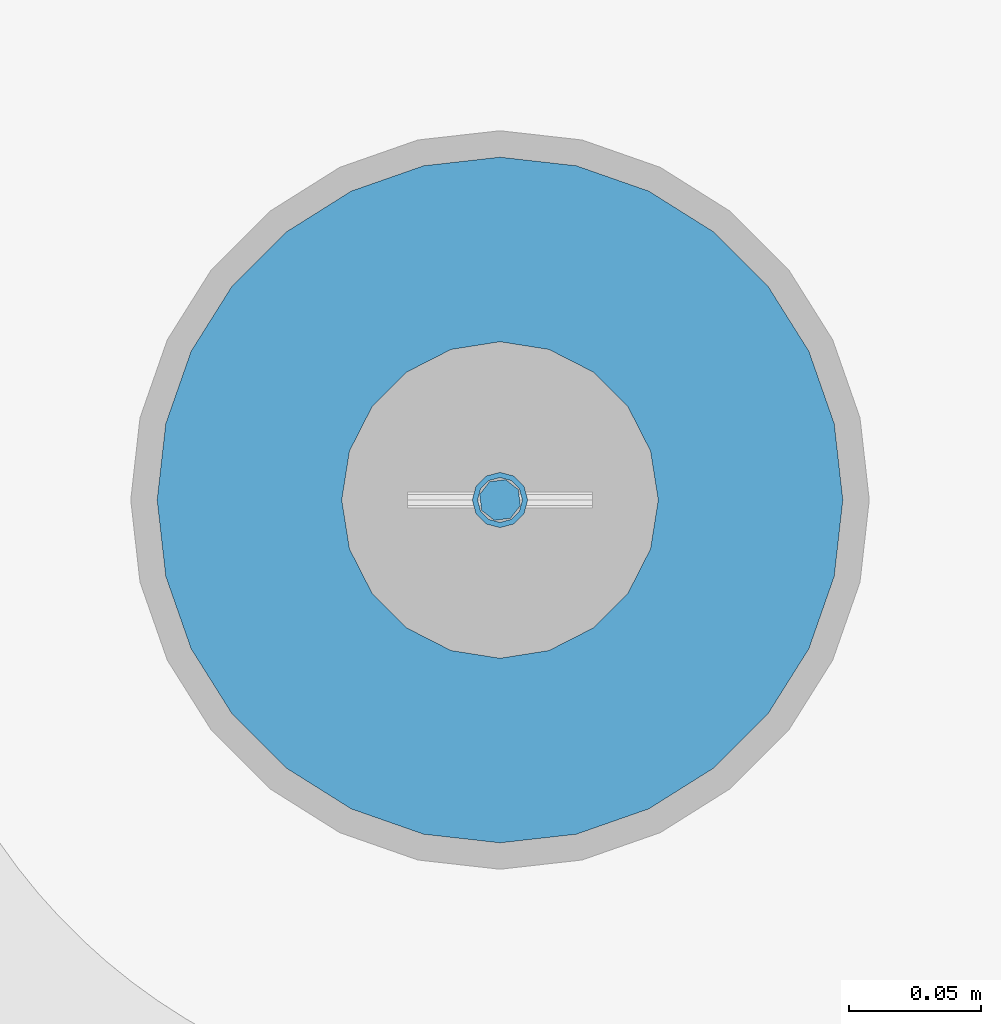
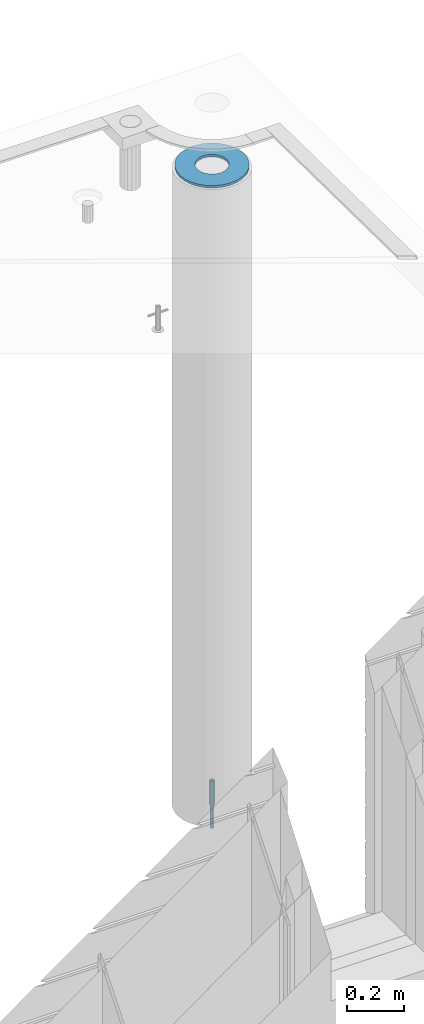
# One storey, part 38 of 352: 3 columns, 3 elements without a shape of their own.
"""IFC2X3 building model written with IfcOpenShell, lengths in millimetres."""

from ifc_helpers import new_model, si_unit, frame, origin_with_axes, place, context, subcontext, project, spatial, faceted_brep, material, type_object, element, aggregate, save


model = new_model("IFC2X3")

# Units and contexts
model_context = context("Model", 3, precision=1e-05, world=origin_with_axes())
body_context = subcontext(model_context, "Body", "Model", "MODEL_VIEW")
ifc_project = project(units=[si_unit("LENGTHUNIT", "METRE", prefix="MILLI"), si_unit("AREAUNIT", "SQUARE_METRE"), si_unit("VOLUMEUNIT", "CUBIC_METRE"), si_unit("MASSUNIT", "GRAM", prefix="KILO"), si_unit("TIMEUNIT", "SECOND"), si_unit("PLANEANGLEUNIT", "RADIAN"), si_unit("SOLIDANGLEUNIT", "STERADIAN"), si_unit("THERMODYNAMICTEMPERATUREUNIT", "DEGREE_CELSIUS"), si_unit("LUMINOUSINTENSITYUNIT", "LUMEN")], contexts=[model_context])

# Site, building, storey
site_placement = place(None, origin_with_axes())
site = spatial("IfcSite", under=ifc_project, at=site_placement, CompositionType="ELEMENT")
building_placement = place(site_placement, origin_with_axes())
building = spatial("IfcBuilding", under=site, at=building_placement, CompositionType="ELEMENT")
storey_placement = place(building_placement, origin_with_axes())
storey = spatial("IfcBuildingStorey", under=building, at=storey_placement, Name="6", CompositionType="ELEMENT", Elevation=0.0)

# Assemblies, columns
assembly_1_placement = place(storey_placement, origin_with_axes())
assembly_1 = element("IfcElementAssembly", 1, at=assembly_1_placement, inside=storey, AssemblyPlace="NOTDEFINED", PredefinedType="REINFORCEMENT_UNIT")
assembly_2_placement = place(assembly_1_placement, origin_with_axes())
assembly_2 = element("IfcElementAssembly", 2, at=assembly_2_placement, Name="Steel Assembly", AssemblyPlace="NOTDEFINED", PredefinedType="RIGID_FRAME")
ifc_material_1 = material(Name="STEEL/S235JR")
column_type_1 = type_object("IfcColumnType", Name="D16", PredefinedType="NOTDEFINED")
column_1_placement = place(assembly_2_placement, frame((35010.0004801435, 22669.9842012047, 96625.0), z_axis=(-0.261346946111888, -0.96524492941325, 0.0), x_axis=(0.0, 0.0, 1.0)))
column_1 = element("IfcColumn", 3, at=column_1_placement, type_object=column_type_1, material=ifc_material_1, Name="M16", ObjectType="D16", context=body_context, shape_type="Brep", body=[
    faceted_brep([(0.0, -8.0, 0.0), (0.0, -5.65685424949334, -5.65685424949334), (150.0, -5.65685424949697, -5.65685424949334), (150.0, -8.00000000000364, 0.0), (0.0, 0.0, -8.0), (150.0, -7.27595761418343e-12, -7.99999999999636), (0.0, 5.65685424949334, -5.65685424949334), (150.0, 5.6568542494897, -5.65685424949334), (0.0, 8.0, 0.0), (150.0, 8.0, -3.63797880709171e-12), (0.0, 5.65685424949334, 5.65685424949334), (150.0, 5.65685424949334, 5.65685424949697), (0.0, 0.0, 8.0), (150.0, -3.63797880709171e-12, 8.0), (0.0, -5.65685424949334, 5.65685424949334), (150.0, -5.65685424949334, 5.6568542494897)], [[[0, 1, 2, 3]], [[1, 4, 5, 2]], [[4, 6, 7, 5]], [[6, 8, 9, 7]], [[8, 10, 11, 9]], [[10, 12, 13, 11]], [[12, 14, 15, 13]], [[14, 0, 3, 15]], [[5, 7, 9, 11, 13, 15, 3, 2]], [[14, 12, 10, 8, 6, 4, 1, 0]]]),
])
aggregate(assembly_2, [column_1])
assembly_3_placement = place(assembly_1_placement, origin_with_axes())
assembly_3 = element("IfcElementAssembly", 4, at=assembly_3_placement, Name="Steel Assembly", AssemblyPlace="NOTDEFINED", PredefinedType="RIGID_FRAME")
ifc_material_2 = material(Name="STEEL/Steel_Undefined")
column_type_2 = type_object("IfcColumnType", PredefinedType="NOTDEFINED")
column_2_placement = place(assembly_3_placement, frame((35009.9987952044, 22669.984888838, 96725.0), z_axis=(0.0, 1.0, 0.0), x_axis=(0.0, 0.0, 1.0)))
column_2 = element("IfcColumn", 5, at=column_2_placement, type_object=column_type_2, material=ifc_material_2, context=body_context, shape_type="Brep", body=[
    faceted_brep([(0.0, -8.49999999999272, -1.45519152283669e-11), (0.0, -7.36121593215648, 4.24999999998545), (100.000000000262, -7.36121593215648, 4.24999999998545), (100.000000000262, -8.49999999999272, -1.45519152283669e-11), (0.0, -4.24999999998545, 7.36121593216376), (100.000000000262, -4.24999999998545, 7.36121593216376), (0.0, 1.45519152283669e-11, 8.49999999998545), (100.000000000262, 1.45519152283669e-11, 8.49999999998545), (0.0, 4.25000000001455, 7.36121593216376), (100.000000000262, 4.25000000001455, 7.36121593216376), (0.0, 7.36121593217104, 4.24999999998545), (100.000000000262, 7.36121593217104, 4.24999999998545), (0.0, 8.50000000000728, 0.0), (100.000000000262, 8.50000000000728, 0.0), (0.0, 7.36121593217104, -4.25000000001455), (100.000000000262, 7.36121593217104, -4.25000000001455), (0.0, 4.25000000000728, -7.36121593219286), (100.000000000262, 4.25000000000728, -7.36121593219286), (0.0, 7.27595761418343e-12, -8.5), (100.000000000262, 7.27595761418343e-12, -8.5), (0.0, -4.24999999999272, -7.36121593217831), (100.000000000262, -4.24999999999272, -7.36121593217831), (0.0, -7.36121593215648, -4.25), (100.000000000262, -7.36121593215648, -4.25), (0.0, -10.4999999999927, -1.45519152283669e-11), (0.0, -9.09326673972828, -5.25000000001455), (100.000000000262, -9.09326673972828, -5.25000000001455), (100.000000000262, -10.4999999999927, -1.45519152283669e-11), (0.0, -5.24999999998545, -9.09326673974283), (100.000000000262, -5.24999999998545, -9.09326673974283), (0.0, 7.27595761418343e-12, -10.5), (100.000000000262, 7.27595761418343e-12, -10.5), (0.0, 5.25000000001455, -9.09326673975738), (100.000000000262, 5.25000000001455, -9.09326673975738), (0.0, 9.09326673975011, -5.25000000001455), (100.000000000262, 9.09326673975011, -5.25000000001455), (0.0, 10.5000000000073, -1.45519152283669e-11), (100.000000000262, 10.5000000000073, -1.45519152283669e-11), (0.0, 9.09326673975011, 5.25), (100.000000000262, 9.09326673975011, 5.25), (0.0, 5.25000000000728, 9.09326673972828), (100.000000000262, 5.25000000000728, 9.09326673972828), (0.0, 1.45519152283669e-11, 10.4999999999854), (100.000000000262, 1.45519152283669e-11, 10.4999999999854), (0.0, -5.24999999999272, 9.09326673972828), (100.000000000262, -5.24999999999272, 9.09326673972828), (0.0, -9.09326673972828, 5.24999999998545), (100.000000000262, -9.09326673972828, 5.24999999998545)], [[[0, 1, 2, 3]], [[1, 4, 5, 2]], [[4, 6, 7, 5]], [[6, 8, 9, 7]], [[8, 10, 11, 9]], [[10, 12, 13, 11]], [[12, 14, 15, 13]], [[14, 16, 17, 15]], [[16, 18, 19, 17]], [[18, 20, 21, 19]], [[20, 22, 23, 21]], [[22, 0, 3, 23]], [[24, 25, 26, 27]], [[25, 28, 29, 26]], [[28, 30, 31, 29]], [[30, 32, 33, 31]], [[32, 34, 35, 33]], [[34, 36, 37, 35]], [[36, 38, 39, 37]], [[38, 40, 41, 39]], [[40, 42, 43, 41]], [[42, 44, 45, 43]], [[44, 46, 47, 45]], [[46, 24, 27, 47]], [[29, 31, 33, 35, 37, 39, 41, 43, 45, 47, 27, 26], [5, 7, 9, 11, 13, 15, 17, 19, 21, 23, 3, 2]], [[46, 44, 42, 40, 38, 36, 34, 32, 30, 28, 25, 24], [22, 20, 18, 16, 14, 12, 10, 8, 6, 4, 1, 0]]]),
])
aggregate(assembly_3, [column_2])
ifc_material_3 = material()
column_type_3 = type_object("IfcColumnType", Name="D260", PredefinedType="NOTDEFINED")
column_3_placement = place(assembly_1_placement, frame((35009.9987952044, 22669.984888838, 99435.0), z_axis=(-1.0, 3.00000001838171e-08, 0.0), x_axis=(0.0, 0.0, 1.0)))
column_3 = element("IfcColumn", 6, at=column_3_placement, type_object=column_type_3, material=ifc_material_3, Name="60", ObjectType="D260", context=body_context, shape_type="Brep", body=[
    faceted_brep([(10.0, -18.541019662498, -57.0633909777098), (0.0, -18.541019662498, -57.0633909777098), (0.0, -35.2671151375471, -48.5410196624944), (10.0, -35.2671151375471, -48.5410196624944), (0.0, -48.541019662498, -35.2671151375471), (10.0, -48.541019662498, -35.2671151375471), (0.0, -57.0633909777098, -18.5410196624944), (10.0, -57.0633909777098, -18.5410196624944), (0.0, -60.0, 0.0), (10.0, -60.0, 0.0), (0.0, -57.0633909777098, 18.5410196624944), (10.0, -57.0633909777098, 18.5410196624944), (0.0, -48.541019662498, 35.2671151375471), (10.0, -48.541019662498, 35.2671151375471), (0.0, -35.2671151375471, 48.5410196624944), (10.0, -35.2671151375471, 48.5410196624944), (0.0, -18.541019662498, 57.0633909777098), (10.0, -18.541019662498, 57.0633909777098), (0.0, 0.0, 60.0), (10.0, 0.0, 60.0), (0.0, 18.541019662498, 57.0633909777098), (10.0, 18.541019662498, 57.0633909777098), (0.0, 35.2671151375471, 48.5410196624944), (10.0, 35.2671151375471, 48.5410196624944), (0.0, 48.541019662498, 35.2671151375471), (10.0, 48.541019662498, 35.2671151375471), (0.0, 57.0633909777098, 18.5410196624944), (10.0, 57.0633909777098, 18.5410196624944), (0.0, 60.0, 0.0), (10.0, 60.0, 0.0), (0.0, 57.0633909777098, -18.5410196624944), (10.0, 57.0633909777098, -18.5410196624944), (0.0, 48.541019662498, -35.2671151375471), (10.0, 48.541019662498, -35.2671151375471), (0.0, 35.2671151375471, -48.5410196624944), (10.0, 35.2671151375471, -48.5410196624944), (0.0, 18.541019662498, -57.0633909777098), (10.0, 18.541019662498, -57.0633909777098), (0.0, 0.0, -60.0), (10.0, 0.0, -60.0), (0.0, -126.740628583637, -28.9277214143222), (0.0, -117.125952827315, -56.4048860852854), (10.0, -117.125952827315, -56.4048860852854), (10.0, -126.740628583637, -28.9277214143222), (0.0, -101.638092720845, -81.0536742416371), (10.0, -101.638092720845, -81.0536742416371), (0.0, -81.0536742416371, -101.638092720845), (10.0, -81.0536742416371, -101.638092720845), (0.0, -56.4048860852818, -117.125952827315), (10.0, -56.4048860852818, -117.125952827315), (0.0, -28.9277214143222, -126.740628583641), (10.0, -28.9277214143222, -126.740628583641), (0.0, 0.0, -130.0), (10.0, 0.0, -130.0), (0.0, 28.9277214143222, -126.740628583641), (10.0, 28.9277214143222, -126.740628583641), (0.0, 56.4048860852818, -117.125952827315), (10.0, 56.4048860852818, -117.125952827315), (0.0, 81.0536742416371, -101.638092720845), (10.0, 81.0536742416371, -101.638092720845), (0.0, 101.638092720845, -81.0536742416371), (10.0, 101.638092720845, -81.0536742416371), (0.0, 117.125952827315, -56.4048860852854), (10.0, 117.125952827315, -56.4048860852854), (0.0, 126.740628583637, -28.9277214143222), (10.0, 126.740628583637, -28.9277214143222), (0.0, 130.0, -1.81898940354586e-12), (10.0, 130.0, 0.0), (0.0, 126.740628583637, 28.9277214143222), (10.0, 126.740628583637, 28.9277214143222), (0.0, 117.125952827315, 56.4048860852854), (10.0, 117.125952827315, 56.4048860852854), (0.0, 101.638092720845, 81.0536742416371), (10.0, 101.638092720845, 81.0536742416371), (0.0, 81.0536742416371, 101.638092720845), (10.0, 81.0536742416371, 101.638092720845), (0.0, 56.4048860852818, 117.125952827315), (10.0, 56.4048860852818, 117.125952827315), (0.0, 28.9277214143222, 126.740628583641), (10.0, 28.9277214143222, 126.740628583641), (0.0, 0.0, 130.0), (10.0, 0.0, 130.0), (0.0, -28.9277214143222, 126.740628583641), (10.0, -28.9277214143222, 126.740628583641), (0.0, -56.4048860852818, 117.125952827315), (10.0, -56.4048860852818, 117.125952827315), (0.0, -81.0536742416371, 101.638092720845), (10.0, -81.0536742416371, 101.638092720845), (0.0, -101.638092720845, 81.0536742416371), (10.0, -101.638092720845, 81.0536742416371), (0.0, -117.125952827315, 56.4048860852854), (10.0, -117.125952827315, 56.4048860852854), (0.0, -126.740628583637, 28.9277214143222), (10.0, -126.740628583637, 28.9277214143222), (0.0, -130.0, -3.63797880709171e-12), (10.0, -130.0, 0.0)], [[[0, 1, 2, 3]], [[3, 2, 4, 5]], [[5, 4, 6, 7]], [[7, 6, 8, 9]], [[9, 8, 10, 11]], [[11, 10, 12, 13]], [[13, 12, 14, 15]], [[15, 14, 16, 17]], [[17, 16, 18, 19]], [[19, 18, 20, 21]], [[21, 20, 22, 23]], [[23, 22, 24, 25]], [[25, 24, 26, 27]], [[27, 26, 28, 29]], [[29, 28, 30, 31]], [[31, 30, 32, 33]], [[33, 32, 34, 35]], [[35, 34, 36, 37]], [[37, 36, 38, 39]], [[39, 38, 1, 0]], [[40, 41, 42, 43]], [[41, 44, 45, 42]], [[44, 46, 47, 45]], [[46, 48, 49, 47]], [[48, 50, 51, 49]], [[50, 52, 53, 51]], [[52, 54, 55, 53]], [[54, 56, 57, 55]], [[56, 58, 59, 57]], [[58, 60, 61, 59]], [[60, 62, 63, 61]], [[62, 64, 65, 63]], [[64, 66, 67, 65]], [[66, 68, 69, 67]], [[68, 70, 71, 69]], [[70, 72, 73, 71]], [[72, 74, 75, 73]], [[74, 76, 77, 75]], [[76, 78, 79, 77]], [[78, 80, 81, 79]], [[80, 82, 83, 81]], [[82, 84, 85, 83]], [[84, 86, 87, 85]], [[86, 88, 89, 87]], [[88, 90, 91, 89]], [[90, 92, 93, 91]], [[92, 94, 95, 93]], [[42, 45, 47, 49, 51, 53, 55, 57, 59, 61, 63, 65, 67, 69, 71, 73, 75, 77, 79, 81, 83, 85, 87, 89, 91, 93, 95, 43], [3, 5, 7, 9, 11, 13, 15, 17, 19, 21, 23, 25, 27, 29, 31, 33, 35, 37, 39, 0]], [[94, 40, 43, 95]], [[92, 90, 88, 86, 84, 82, 80, 78, 76, 74, 72, 70, 68, 66, 64, 62, 60, 58, 56, 54, 52, 50, 48, 46, 44, 41, 40, 94], [34, 32, 30, 28, 26, 24, 22, 20, 18, 16, 14, 12, 10, 8, 6, 4, 2, 1, 38, 36]]]),
])
aggregate(assembly_1, [assembly_3, assembly_2, column_3])

save(model, "model.ifc")
